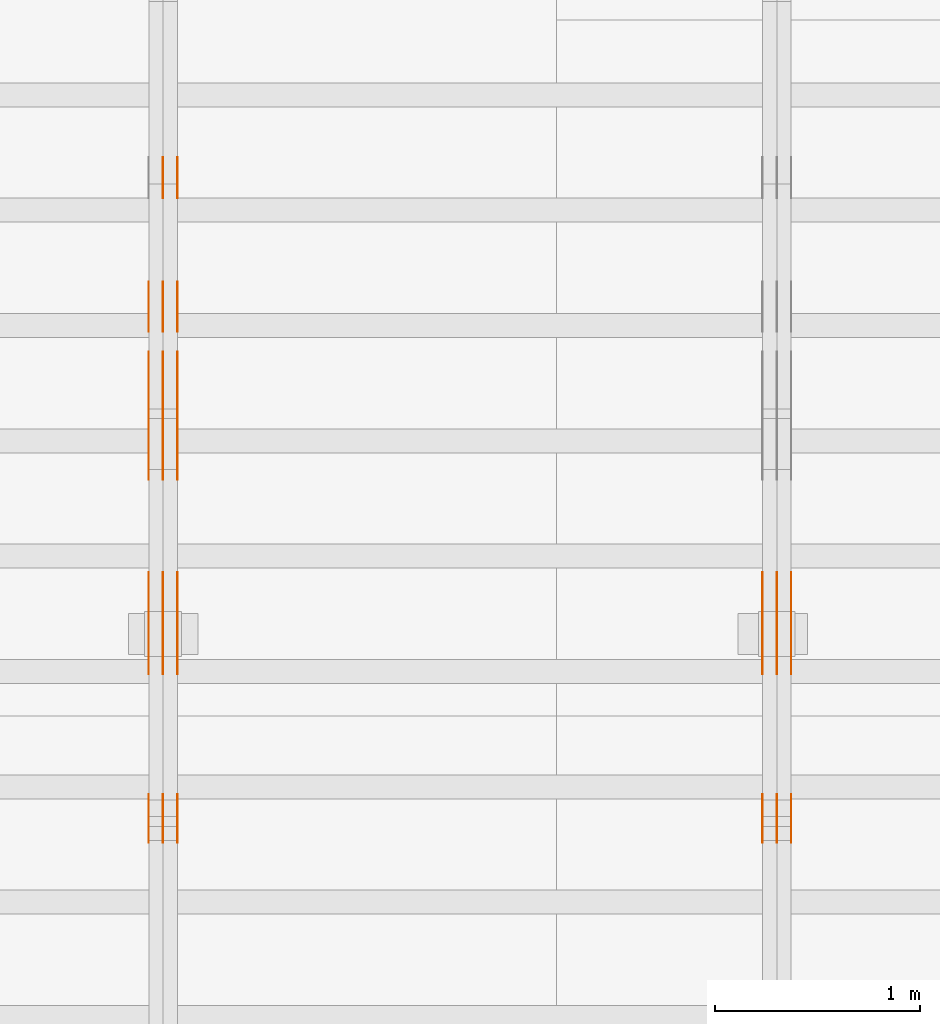
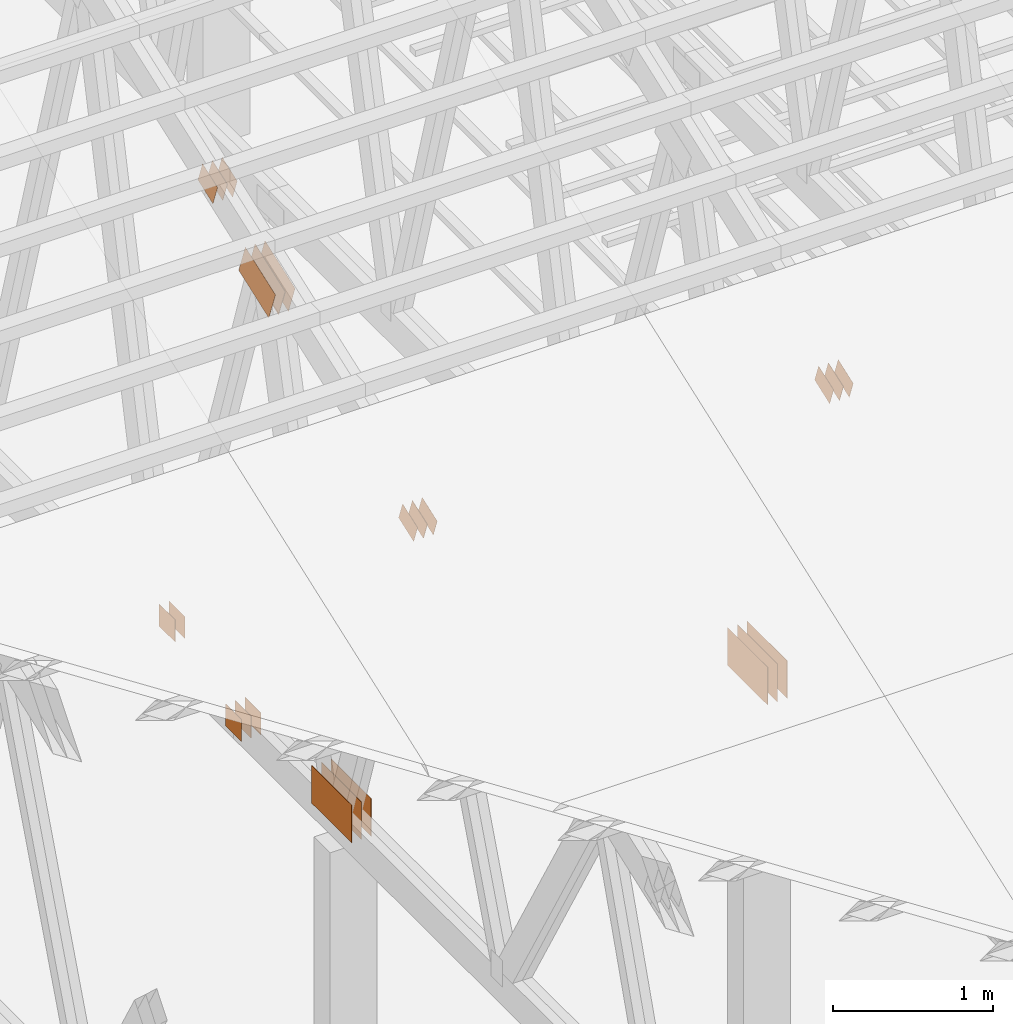
# One storey, part 148 of 189: 31 proxies.
"""IFC2X3 building model written with IfcOpenShell, lengths in millimetres."""

from ifc_helpers import new_model, entity, si_unit, converted_unit, derived_unit, direction, frame, frame_2d, origin, origin_2d_with_axis, place, context, subcontext, project, spatial, polyline, rectangle, outline, extrude, source, transform, mapped, material, type_object, type_shapes, element, save


model = new_model("IFC2X3")

# Units and contexts
model_context = context("Model", 3, precision=0.01, world=origin(), true_north=direction((6.12303176911189e-17, 1.0)))
body_context = subcontext(model_context, "Body", "Model", "MODEL_VIEW")
ifc_project = project(units=[si_unit("LENGTHUNIT", "METRE", prefix="MILLI"), si_unit("AREAUNIT", "SQUARE_METRE"), si_unit("VOLUMEUNIT", "CUBIC_METRE"), converted_unit("PLANEANGLEUNIT", "DEGREE", entity("IfcRatioMeasure", 0.0174532925199433), si_unit("PLANEANGLEUNIT", "RADIAN"), dimensions=[0, 0, 0, 0, 0, 0, 0]), si_unit("MASSUNIT", "GRAM", prefix="KILO"), derived_unit("MASSDENSITYUNIT", [(si_unit("MASSUNIT", "GRAM", prefix="KILO"), 1), (si_unit("LENGTHUNIT", "METRE"), -3)]), si_unit("TIMEUNIT", "SECOND"), si_unit("FREQUENCYUNIT", "HERTZ"), si_unit("THERMODYNAMICTEMPERATUREUNIT", "DEGREE_CELSIUS"), derived_unit("THERMALTRANSMITTANCEUNIT", [(si_unit("MASSUNIT", "GRAM", prefix="KILO"), 1), (si_unit("THERMODYNAMICTEMPERATUREUNIT", "KELVIN"), -1), (si_unit("TIMEUNIT", "SECOND"), -3)]), derived_unit("VOLUMETRICFLOWRATEUNIT", [(si_unit("LENGTHUNIT", "METRE"), 3), (si_unit("TIMEUNIT", "SECOND"), -1)]), si_unit("ELECTRICCURRENTUNIT", "AMPERE"), si_unit("ELECTRICVOLTAGEUNIT", "VOLT"), si_unit("POWERUNIT", "WATT"), si_unit("FORCEUNIT", "NEWTON"), si_unit("ILLUMINANCEUNIT", "LUX"), si_unit("LUMINOUSFLUXUNIT", "LUMEN"), si_unit("LUMINOUSINTENSITYUNIT", "CANDELA"), derived_unit("USERDEFINED", [(si_unit("MASSUNIT", "GRAM", prefix="KILO"), -1), (si_unit("LENGTHUNIT", "METRE"), -2), (si_unit("TIMEUNIT", "SECOND"), 3), (si_unit("LUMINOUSFLUXUNIT", "LUMEN"), 1)]), derived_unit("LINEARVELOCITYUNIT", [(si_unit("LENGTHUNIT", "METRE"), 1), (si_unit("TIMEUNIT", "SECOND"), -1)]), si_unit("PRESSUREUNIT", "PASCAL"), derived_unit("USERDEFINED", [(si_unit("LENGTHUNIT", "METRE"), -2), (si_unit("MASSUNIT", "GRAM", prefix="KILO"), 1), (si_unit("TIMEUNIT", "SECOND"), -2)])], contexts=[model_context])

# Site, building, storey
site_placement = place(None, origin())
site = spatial("IfcSite", under=ifc_project, at=site_placement, CompositionType="ELEMENT")
building_placement = place(site_placement, origin())
building = spatial("IfcBuilding", under=site, at=building_placement, CompositionType="ELEMENT")
storey_placement = place(building_placement, origin())
storey = spatial("IfcBuildingStorey", under=building, at=storey_placement, Name="Default", CompositionType="ELEMENT", Elevation=0.0)

# Proxies
ifc_material_1 = material(Name="IfcSurfaceStyle #233938")
building_element_proxy_type_1 = type_object("IfcBuildingElementProxyType", PredefinedType="NOTDEFINED", material=ifc_material_1)
shared_shape_1 = source(origin(), body_context, "Body", "SweptSolid", [
    extrude(rectangle(XDim=500.0, YDim=288.0, at=frame_2d((0.0, 1.4210854715202e-14), x_axis=(1.0, 0.0))), frame((250.000973740011, 144.0, 0.0), z_axis=(0.0, 0.0, 1.0), x_axis=(-1.0, 0.0, 0.0)), (0.0, 0.0, 1.0), 1.29999999999998),
])
type_shapes(building_element_proxy_type_1, [shared_shape_1])
proxy_1_placement = place(building_placement, frame((42301.3, 8551.90918250999, 389.0), z_axis=(-1.0, 0.0, 0.0), x_axis=(0.0, 1.0, 0.0)))
element("IfcBuildingElementProxy", 1, at=proxy_1_placement, inside=storey, type_object=building_element_proxy_type_1, material=ifc_material_1, context=body_context, shape_type="MappedRepresentation", body=[
    mapped(shared_shape_1, transform((0.0, 0.0, 0.0), scale=1.0)),
])
ifc_material_2 = material(Name="IfcSurfaceStyle #233881")
building_element_proxy_type_2 = type_object("IfcBuildingElementProxyType", PredefinedType="NOTDEFINED", material=ifc_material_2)
shared_shape_2 = source(origin(), body_context, "Body", "SweptSolid", [
    extrude(rectangle(XDim=500.0, YDim=288.0, at=frame_2d((0.0, 1.4210854715202e-14), x_axis=(1.0, 0.0))), frame((250.000973740011, 144.0, 0.0), z_axis=(0.0, 0.0, 1.0), x_axis=(-1.0, 0.0, 0.0)), (0.0, 0.0, 1.0), 1.29999999999997),
])
type_shapes(building_element_proxy_type_2, [shared_shape_2])
proxy_2_placement = place(building_placement, frame((42230.0, 8551.90918250999, 389.0), z_axis=(-1.0, 0.0, 0.0), x_axis=(0.0, 1.0, 0.0)))
element("IfcBuildingElementProxy", 2, at=proxy_2_placement, inside=storey, type_object=building_element_proxy_type_2, material=ifc_material_2, context=body_context, shape_type="MappedRepresentation", body=[
    mapped(shared_shape_2, transform((0.0, 0.0, 0.0), scale=1.0)),
])
ifc_material_3 = material(Name="IfcSurfaceStyle #233824")
building_element_proxy_type_3 = type_object("IfcBuildingElementProxyType", PredefinedType="NOTDEFINED", material=ifc_material_3)
shared_shape_3 = source(origin(), body_context, "Body", "SweptSolid", [
    extrude(rectangle(XDim=500.0, YDim=288.0, at=frame_2d((0.0, 1.4210854715202e-14), x_axis=(1.0, 0.0))), frame((250.000973740011, 144.0, 0.0), z_axis=(0.0, 0.0, 1.0), x_axis=(-1.0, 0.0, 0.0)), (0.0, 0.0, 1.0), 1.29999999999997),
])
type_shapes(building_element_proxy_type_3, [shared_shape_3])
proxy_3_placement = place(building_placement, frame((42231.3, 8551.90918250999, 389.0), z_axis=(-1.0, 0.0, 0.0), x_axis=(0.0, 1.0, 0.0)))
element("IfcBuildingElementProxy", 3, at=proxy_3_placement, inside=storey, type_object=building_element_proxy_type_3, material=ifc_material_3, context=body_context, shape_type="MappedRepresentation", body=[
    mapped(shared_shape_3, transform((0.0, 0.0, 0.0), scale=1.0)),
])
ifc_material_4 = material(Name="IfcSurfaceStyle #233767")
building_element_proxy_type_4 = type_object("IfcBuildingElementProxyType", PredefinedType="NOTDEFINED", material=ifc_material_4)
shared_shape_4 = source(origin(), body_context, "Body", "SweptSolid", [
    extrude(rectangle(XDim=500.0, YDim=288.0, at=frame_2d((0.0, 1.4210854715202e-14), x_axis=(1.0, 0.0))), frame((250.000973740011, 144.0, 0.0), z_axis=(0.0, 0.0, 1.0), x_axis=(-1.0, 0.0, 0.0)), (0.0, 0.0, 1.0), 1.29999999999997),
])
type_shapes(building_element_proxy_type_4, [shared_shape_4])
proxy_4_placement = place(building_placement, frame((42160.0, 8551.90918250999, 389.0), z_axis=(-1.0, 0.0, 0.0), x_axis=(0.0, 1.0, 0.0)))
element("IfcBuildingElementProxy", 4, at=proxy_4_placement, inside=storey, type_object=building_element_proxy_type_4, material=ifc_material_4, context=body_context, shape_type="MappedRepresentation", body=[
    mapped(shared_shape_4, transform((0.0, 0.0, 0.0), scale=1.0)),
])
ifc_material_5 = material(Name="IfcSurfaceStyle #233710")
building_element_proxy_type_5 = type_object("IfcBuildingElementProxyType", PredefinedType="NOTDEFINED", material=ifc_material_5)
shared_shape_5 = source(origin(), body_context, "Body", "SweptSolid", [
    extrude(outline(polyline([(-100.00048713087, -72.0000025659129), (100.000394045495, -72.0000025659129), (99.9995694622958, 72.0000025659129), (-99.9994763769209, 72.0000025659128), (-100.00048713087, -72.0000025659129)])), frame((100.000394045495, 72.0000025659128, 0.0), z_axis=(0.0, 0.0, 1.0), x_axis=(-1.0, 0.0, 0.0)), (0.0, 0.0, 1.0), 1.3),
])
type_shapes(building_element_proxy_type_5, [shared_shape_5])
proxy_5_placement = place(building_placement, frame((42301.3, 7965.16887114408, 2936.19963864386), z_axis=(-1.0, 0.0, 0.0), x_axis=(0.0, -0.939692620785908, -0.342020143325669)))
element("IfcBuildingElementProxy", 5, at=proxy_5_placement, inside=storey, type_object=building_element_proxy_type_5, material=ifc_material_5, context=body_context, shape_type="MappedRepresentation", body=[
    mapped(shared_shape_5, transform((0.0, 0.0, 0.0), scale=1.0)),
])
ifc_material_6 = material(Name="IfcSurfaceStyle #233653")
building_element_proxy_type_6 = type_object("IfcBuildingElementProxyType", PredefinedType="NOTDEFINED", material=ifc_material_6)
shared_shape_6 = source(origin(), body_context, "Body", "SweptSolid", [
    extrude(outline(polyline([(-100.00048713087, -72.0000025659129), (100.000394045495, -72.0000025659129), (99.9995694622958, 72.0000025659129), (-99.9994763769209, 72.0000025659128), (-100.00048713087, -72.0000025659129)])), frame((100.000394045495, 72.0000025659128, 0.0), z_axis=(0.0, 0.0, 1.0), x_axis=(-1.0, 0.0, 0.0)), (0.0, 0.0, 1.0), 1.29999999999998),
])
type_shapes(building_element_proxy_type_6, [shared_shape_6])
proxy_6_placement = place(building_placement, frame((42230.0, 7965.16887114408, 2936.19963864386), z_axis=(-1.0, 0.0, 0.0), x_axis=(0.0, -0.939692620785908, -0.342020143325669)))
element("IfcBuildingElementProxy", 6, at=proxy_6_placement, inside=storey, type_object=building_element_proxy_type_6, material=ifc_material_6, context=body_context, shape_type="MappedRepresentation", body=[
    mapped(shared_shape_6, transform((0.0, 0.0, 0.0), scale=1.0)),
])
ifc_material_7 = material(Name="IfcSurfaceStyle #233596")
building_element_proxy_type_7 = type_object("IfcBuildingElementProxyType", PredefinedType="NOTDEFINED", material=ifc_material_7)
shared_shape_7 = source(origin(), body_context, "Body", "SweptSolid", [
    extrude(outline(polyline([(-100.00048713087, -72.0000025659129), (100.000394045495, -72.0000025659129), (99.9995694622958, 72.0000025659129), (-99.9994763769209, 72.0000025659128), (-100.00048713087, -72.0000025659129)])), frame((100.000394045495, 72.0000025659128, 0.0), z_axis=(0.0, 0.0, 1.0), x_axis=(-1.0, 0.0, 0.0)), (0.0, 0.0, 1.0), 1.29999999999998),
])
type_shapes(building_element_proxy_type_7, [shared_shape_7])
proxy_7_placement = place(building_placement, frame((42231.3, 7965.16887114408, 2936.19963864386), z_axis=(-1.0, 0.0, 0.0), x_axis=(0.0, -0.939692620785908, -0.342020143325669)))
element("IfcBuildingElementProxy", 7, at=proxy_7_placement, inside=storey, type_object=building_element_proxy_type_7, material=ifc_material_7, context=body_context, shape_type="MappedRepresentation", body=[
    mapped(shared_shape_7, transform((0.0, 0.0, 0.0), scale=1.0)),
])
ifc_material_8 = material(Name="IfcSurfaceStyle #233539")
building_element_proxy_type_8 = type_object("IfcBuildingElementProxyType", PredefinedType="NOTDEFINED", material=ifc_material_8)
shared_shape_8 = source(origin(), body_context, "Body", "SweptSolid", [
    extrude(outline(polyline([(-100.00048713087, -72.0000025659129), (100.000394045495, -72.0000025659129), (99.9995694622958, 72.0000025659129), (-99.9994763769209, 72.0000025659128), (-100.00048713087, -72.0000025659129)])), frame((100.000394045495, 72.0000025659128, 0.0), z_axis=(0.0, 0.0, 1.0), x_axis=(-1.0, 0.0, 0.0)), (0.0, 0.0, 1.0), 1.29999999999999),
])
type_shapes(building_element_proxy_type_8, [shared_shape_8])
proxy_8_placement = place(building_placement, frame((42160.0, 7965.16887114408, 2936.19963864386), z_axis=(-1.0, 0.0, 0.0), x_axis=(0.0, -0.939692620785908, -0.342020143325669)))
element("IfcBuildingElementProxy", 8, at=proxy_8_placement, inside=storey, type_object=building_element_proxy_type_8, material=ifc_material_8, context=body_context, shape_type="MappedRepresentation", body=[
    mapped(shared_shape_8, transform((0.0, 0.0, 0.0), scale=1.0)),
])
ifc_material_9 = material(Name="IfcSurfaceStyle #219060")
building_element_proxy_type_9 = type_object("IfcBuildingElementProxyType", PredefinedType="NOTDEFINED", material=ifc_material_9)
shared_shape_9 = source(origin(), body_context, "Body", "SweptSolid", [
    extrude(rectangle(XDim=200.0, YDim=168.0, at=origin_2d_with_axis()), frame((100.000765376775, 84.0, 0.0), z_axis=(0.0, 0.0, 1.0), x_axis=(-1.0, 0.0, 0.0)), (0.0, 0.0, 1.0), 1.3),
])
type_shapes(building_element_proxy_type_9, [shared_shape_9])
proxy_9_placement = place(building_placement, frame((39301.3, 10880.1574377482, 365.0), z_axis=(-1.0, 0.0, 0.0), x_axis=(0.0, 1.0, 0.0)))
element("IfcBuildingElementProxy", 9, at=proxy_9_placement, inside=storey, type_object=building_element_proxy_type_9, material=ifc_material_9, context=body_context, shape_type="MappedRepresentation", body=[
    mapped(shared_shape_9, transform((0.0, 0.0, 0.0), scale=1.0)),
])
ifc_material_10 = material(Name="IfcSurfaceStyle #219003")
building_element_proxy_type_10 = type_object("IfcBuildingElementProxyType", PredefinedType="NOTDEFINED", material=ifc_material_10)
shared_shape_10 = source(origin(), body_context, "Body", "SweptSolid", [
    extrude(rectangle(XDim=200.0, YDim=168.0, at=origin_2d_with_axis()), frame((100.000765376775, 84.0, 0.0), z_axis=(0.0, 0.0, 1.0), x_axis=(-1.0, 0.0, 0.0)), (0.0, 0.0, 1.0), 1.29999999999998),
])
type_shapes(building_element_proxy_type_10, [shared_shape_10])
proxy_10_placement = place(building_placement, frame((39230.0, 10880.1574377482, 365.0), z_axis=(-1.0, 0.0, 0.0), x_axis=(0.0, 1.0, 0.0)))
element("IfcBuildingElementProxy", 10, at=proxy_10_placement, inside=storey, type_object=building_element_proxy_type_10, material=ifc_material_10, context=body_context, shape_type="MappedRepresentation", body=[
    mapped(shared_shape_10, transform((0.0, 0.0, 0.0), scale=1.0)),
])
ifc_material_11 = material(Name="IfcSurfaceStyle #218946")
building_element_proxy_type_11 = type_object("IfcBuildingElementProxyType", PredefinedType="NOTDEFINED", material=ifc_material_11)
shared_shape_11 = source(origin(), body_context, "Body", "SweptSolid", [
    extrude(rectangle(XDim=200.0, YDim=168.0, at=origin_2d_with_axis()), frame((100.000765376775, 84.0, 0.0), z_axis=(0.0, 0.0, 1.0), x_axis=(-1.0, 0.0, 0.0)), (0.0, 0.0, 1.0), 1.29999999999998),
])
type_shapes(building_element_proxy_type_11, [shared_shape_11])
proxy_11_placement = place(building_placement, frame((39231.3, 10880.1574377482, 365.0), z_axis=(-1.0, 0.0, 0.0), x_axis=(0.0, 1.0, 0.0)))
element("IfcBuildingElementProxy", 11, at=proxy_11_placement, inside=storey, type_object=building_element_proxy_type_11, material=ifc_material_11, context=body_context, shape_type="MappedRepresentation", body=[
    mapped(shared_shape_11, transform((0.0, 0.0, 0.0), scale=1.0)),
])
ifc_material_12 = material(Name="IfcSurfaceStyle #218832")
building_element_proxy_type_12 = type_object("IfcBuildingElementProxyType", PredefinedType="NOTDEFINED", material=ifc_material_12)
shared_shape_12 = source(origin(), body_context, "Body", "SweptSolid", [
    extrude(outline(polyline([(-199.999582244654, -119.99984375717), (200.000344770932, -119.99984375717), (199.999582244655, 119.99984375717), (-200.000344770934, 119.99984375717), (-199.999582244654, -119.99984375717)])), frame((200.000344770932, 120.0000091947, 0.0), z_axis=(0.0, 0.0, 1.0), x_axis=(-1.0, 0.0, 0.0)), (0.0, 0.0, 1.0), 1.29999999999999),
])
type_shapes(building_element_proxy_type_12, [shared_shape_12])
proxy_12_placement = place(building_placement, frame((39301.3, 9961.90704972973, 3612.2451494258), z_axis=(-1.0, 0.0, 0.0), x_axis=(0.0, -0.939692620785908, -0.342020143325669)))
element("IfcBuildingElementProxy", 12, at=proxy_12_placement, inside=storey, type_object=building_element_proxy_type_12, material=ifc_material_12, context=body_context, shape_type="MappedRepresentation", body=[
    mapped(shared_shape_12, transform((0.0, 0.0, 0.0), scale=1.0)),
])
ifc_material_13 = material(Name="IfcSurfaceStyle #218775")
building_element_proxy_type_13 = type_object("IfcBuildingElementProxyType", PredefinedType="NOTDEFINED", material=ifc_material_13)
shared_shape_13 = source(origin(), body_context, "Body", "SweptSolid", [
    extrude(outline(polyline([(-199.999582244654, -119.99984375717), (200.000344770932, -119.99984375717), (199.999582244655, 119.99984375717), (-200.000344770934, 119.99984375717), (-199.999582244654, -119.99984375717)])), frame((200.000344770932, 120.0000091947, 0.0), z_axis=(0.0, 0.0, 1.0), x_axis=(-1.0, 0.0, 0.0)), (0.0, 0.0, 1.0), 1.29999999999997),
])
type_shapes(building_element_proxy_type_13, [shared_shape_13])
proxy_13_placement = place(building_placement, frame((39230.0, 9961.90704972973, 3612.2451494258), z_axis=(-1.0, 0.0, 0.0), x_axis=(0.0, -0.939692620785908, -0.342020143325669)))
element("IfcBuildingElementProxy", 13, at=proxy_13_placement, inside=storey, type_object=building_element_proxy_type_13, material=ifc_material_13, context=body_context, shape_type="MappedRepresentation", body=[
    mapped(shared_shape_13, transform((0.0, 0.0, 0.0), scale=1.0)),
])
ifc_material_14 = material(Name="IfcSurfaceStyle #218718")
building_element_proxy_type_14 = type_object("IfcBuildingElementProxyType", PredefinedType="NOTDEFINED", material=ifc_material_14)
shared_shape_14 = source(origin(), body_context, "Body", "SweptSolid", [
    extrude(outline(polyline([(-199.999582244654, -119.99984375717), (200.000344770932, -119.99984375717), (199.999582244655, 119.99984375717), (-200.000344770934, 119.99984375717), (-199.999582244654, -119.99984375717)])), frame((200.000344770932, 120.0000091947, 0.0), z_axis=(0.0, 0.0, 1.0), x_axis=(-1.0, 0.0, 0.0)), (0.0, 0.0, 1.0), 1.29999999999997),
])
type_shapes(building_element_proxy_type_14, [shared_shape_14])
proxy_14_placement = place(building_placement, frame((39231.3, 9961.90704972973, 3612.2451494258), z_axis=(-1.0, 0.0, 0.0), x_axis=(0.0, -0.939692620785908, -0.342020143325669)))
element("IfcBuildingElementProxy", 14, at=proxy_14_placement, inside=storey, type_object=building_element_proxy_type_14, material=ifc_material_14, context=body_context, shape_type="MappedRepresentation", body=[
    mapped(shared_shape_14, transform((0.0, 0.0, 0.0), scale=1.0)),
])
ifc_material_15 = material(Name="IfcSurfaceStyle #218661")
building_element_proxy_type_15 = type_object("IfcBuildingElementProxyType", PredefinedType="NOTDEFINED", material=ifc_material_15)
shared_shape_15 = source(origin(), body_context, "Body", "SweptSolid", [
    extrude(outline(polyline([(-199.999582244654, -119.99984375717), (200.000344770932, -119.99984375717), (199.999582244655, 119.99984375717), (-200.000344770934, 119.99984375717), (-199.999582244654, -119.99984375717)])), frame((200.000344770932, 120.0000091947, 0.0), z_axis=(0.0, 0.0, 1.0), x_axis=(-1.0, 0.0, 0.0)), (0.0, 0.0, 1.0), 1.29999999999998),
])
type_shapes(building_element_proxy_type_15, [shared_shape_15])
proxy_15_placement = place(building_placement, frame((39160.0, 9961.90704972973, 3612.2451494258), z_axis=(-1.0, 0.0, 0.0), x_axis=(0.0, -0.939692620785908, -0.342020143325669)))
element("IfcBuildingElementProxy", 15, at=proxy_15_placement, inside=storey, type_object=building_element_proxy_type_15, material=ifc_material_15, context=body_context, shape_type="MappedRepresentation", body=[
    mapped(shared_shape_15, transform((0.0, 0.0, 0.0), scale=1.0)),
])
ifc_material_16 = material(Name="IfcSurfaceStyle #218148")
building_element_proxy_type_16 = type_object("IfcBuildingElementProxyType", PredefinedType="NOTDEFINED", material=ifc_material_16)
shared_shape_16 = source(origin(), body_context, "Body", "SweptSolid", [
    extrude(rectangle(XDim=500.0, YDim=288.0, at=frame_2d((0.0, 1.4210854715202e-14), x_axis=(1.0, 0.0))), frame((250.000973740011, 144.0, 0.0), z_axis=(0.0, 0.0, 1.0), x_axis=(-1.0, 0.0, 0.0)), (0.0, 0.0, 1.0), 1.29999999999998),
])
type_shapes(building_element_proxy_type_16, [shared_shape_16])
proxy_16_placement = place(building_placement, frame((39301.3, 8551.90918250999, 389.0), z_axis=(-1.0, 0.0, 0.0), x_axis=(0.0, 1.0, 0.0)))
element("IfcBuildingElementProxy", 16, at=proxy_16_placement, inside=storey, type_object=building_element_proxy_type_16, material=ifc_material_16, context=body_context, shape_type="MappedRepresentation", body=[
    mapped(shared_shape_16, transform((0.0, 0.0, 0.0), scale=1.0)),
])
ifc_material_17 = material(Name="IfcSurfaceStyle #218091")
building_element_proxy_type_17 = type_object("IfcBuildingElementProxyType", PredefinedType="NOTDEFINED", material=ifc_material_17)
shared_shape_17 = source(origin(), body_context, "Body", "SweptSolid", [
    extrude(rectangle(XDim=500.0, YDim=288.0, at=frame_2d((0.0, 1.4210854715202e-14), x_axis=(1.0, 0.0))), frame((250.000973740011, 144.0, 0.0), z_axis=(0.0, 0.0, 1.0), x_axis=(-1.0, 0.0, 0.0)), (0.0, 0.0, 1.0), 1.29999999999997),
])
type_shapes(building_element_proxy_type_17, [shared_shape_17])
proxy_17_placement = place(building_placement, frame((39230.0, 8551.90918250999, 389.0), z_axis=(-1.0, 0.0, 0.0), x_axis=(0.0, 1.0, 0.0)))
element("IfcBuildingElementProxy", 17, at=proxy_17_placement, inside=storey, type_object=building_element_proxy_type_17, material=ifc_material_17, context=body_context, shape_type="MappedRepresentation", body=[
    mapped(shared_shape_17, transform((0.0, 0.0, 0.0), scale=1.0)),
])
ifc_material_18 = material(Name="IfcSurfaceStyle #218034")
building_element_proxy_type_18 = type_object("IfcBuildingElementProxyType", PredefinedType="NOTDEFINED", material=ifc_material_18)
shared_shape_18 = source(origin(), body_context, "Body", "SweptSolid", [
    extrude(rectangle(XDim=500.0, YDim=288.0, at=frame_2d((0.0, 1.4210854715202e-14), x_axis=(1.0, 0.0))), frame((250.000973740011, 144.0, 0.0), z_axis=(0.0, 0.0, 1.0), x_axis=(-1.0, 0.0, 0.0)), (0.0, 0.0, 1.0), 1.29999999999997),
])
type_shapes(building_element_proxy_type_18, [shared_shape_18])
proxy_18_placement = place(building_placement, frame((39231.3, 8551.90918250999, 389.0), z_axis=(-1.0, 0.0, 0.0), x_axis=(0.0, 1.0, 0.0)))
element("IfcBuildingElementProxy", 18, at=proxy_18_placement, inside=storey, type_object=building_element_proxy_type_18, material=ifc_material_18, context=body_context, shape_type="MappedRepresentation", body=[
    mapped(shared_shape_18, transform((0.0, 0.0, 0.0), scale=1.0)),
])
ifc_material_19 = material(Name="IfcSurfaceStyle #217977")
building_element_proxy_type_19 = type_object("IfcBuildingElementProxyType", PredefinedType="NOTDEFINED", material=ifc_material_19)
shared_shape_19 = source(origin(), body_context, "Body", "SweptSolid", [
    extrude(rectangle(XDim=500.0, YDim=288.0, at=frame_2d((0.0, 1.4210854715202e-14), x_axis=(1.0, 0.0))), frame((250.000973740011, 144.0, 0.0), z_axis=(0.0, 0.0, 1.0), x_axis=(-1.0, 0.0, 0.0)), (0.0, 0.0, 1.0), 1.29999999999997),
])
type_shapes(building_element_proxy_type_19, [shared_shape_19])
proxy_19_placement = place(building_placement, frame((39160.0, 8551.90918250999, 389.0), z_axis=(-1.0, 0.0, 0.0), x_axis=(0.0, 1.0, 0.0)))
element("IfcBuildingElementProxy", 19, at=proxy_19_placement, inside=storey, type_object=building_element_proxy_type_19, material=ifc_material_19, context=body_context, shape_type="MappedRepresentation", body=[
    mapped(shared_shape_19, transform((0.0, 0.0, 0.0), scale=1.0)),
])
ifc_material_20 = material(Name="IfcSurfaceStyle #217920")
building_element_proxy_type_20 = type_object("IfcBuildingElementProxyType", PredefinedType="NOTDEFINED", material=ifc_material_20)
shared_shape_20 = source(origin(), body_context, "Body", "SweptSolid", [
    extrude(outline(polyline([(-100.00048713087, -72.0000025659129), (100.000394045495, -72.0000025659129), (99.9995694622958, 72.0000025659129), (-99.9994763769209, 72.0000025659128), (-100.00048713087, -72.0000025659129)])), frame((100.000394045495, 72.0000025659128, 0.0), z_axis=(0.0, 0.0, 1.0), x_axis=(-1.0, 0.0, 0.0)), (0.0, 0.0, 1.0), 1.3),
])
type_shapes(building_element_proxy_type_20, [shared_shape_20])
proxy_20_placement = place(building_placement, frame((39301.3, 7965.16887114408, 2936.19963864386), z_axis=(-1.0, 0.0, 0.0), x_axis=(0.0, -0.939692620785908, -0.342020143325669)))
element("IfcBuildingElementProxy", 20, at=proxy_20_placement, inside=storey, type_object=building_element_proxy_type_20, material=ifc_material_20, context=body_context, shape_type="MappedRepresentation", body=[
    mapped(shared_shape_20, transform((0.0, 0.0, 0.0), scale=1.0)),
])
ifc_material_21 = material(Name="IfcSurfaceStyle #217863")
building_element_proxy_type_21 = type_object("IfcBuildingElementProxyType", PredefinedType="NOTDEFINED", material=ifc_material_21)
shared_shape_21 = source(origin(), body_context, "Body", "SweptSolid", [
    extrude(outline(polyline([(-100.00048713087, -72.0000025659129), (100.000394045495, -72.0000025659129), (99.9995694622958, 72.0000025659129), (-99.9994763769209, 72.0000025659128), (-100.00048713087, -72.0000025659129)])), frame((100.000394045495, 72.0000025659128, 0.0), z_axis=(0.0, 0.0, 1.0), x_axis=(-1.0, 0.0, 0.0)), (0.0, 0.0, 1.0), 1.29999999999998),
])
type_shapes(building_element_proxy_type_21, [shared_shape_21])
proxy_21_placement = place(building_placement, frame((39230.0, 7965.16887114408, 2936.19963864386), z_axis=(-1.0, 0.0, 0.0), x_axis=(0.0, -0.939692620785908, -0.342020143325669)))
element("IfcBuildingElementProxy", 21, at=proxy_21_placement, inside=storey, type_object=building_element_proxy_type_21, material=ifc_material_21, context=body_context, shape_type="MappedRepresentation", body=[
    mapped(shared_shape_21, transform((0.0, 0.0, 0.0), scale=1.0)),
])
ifc_material_22 = material(Name="IfcSurfaceStyle #217806")
building_element_proxy_type_22 = type_object("IfcBuildingElementProxyType", PredefinedType="NOTDEFINED", material=ifc_material_22)
shared_shape_22 = source(origin(), body_context, "Body", "SweptSolid", [
    extrude(outline(polyline([(-100.00048713087, -72.0000025659129), (100.000394045495, -72.0000025659129), (99.9995694622958, 72.0000025659129), (-99.9994763769209, 72.0000025659128), (-100.00048713087, -72.0000025659129)])), frame((100.000394045495, 72.0000025659128, 0.0), z_axis=(0.0, 0.0, 1.0), x_axis=(-1.0, 0.0, 0.0)), (0.0, 0.0, 1.0), 1.29999999999998),
])
type_shapes(building_element_proxy_type_22, [shared_shape_22])
proxy_22_placement = place(building_placement, frame((39231.3, 7965.16887114408, 2936.19963864386), z_axis=(-1.0, 0.0, 0.0), x_axis=(0.0, -0.939692620785908, -0.342020143325669)))
element("IfcBuildingElementProxy", 22, at=proxy_22_placement, inside=storey, type_object=building_element_proxy_type_22, material=ifc_material_22, context=body_context, shape_type="MappedRepresentation", body=[
    mapped(shared_shape_22, transform((0.0, 0.0, 0.0), scale=1.0)),
])
ifc_material_23 = material(Name="IfcSurfaceStyle #217749")
building_element_proxy_type_23 = type_object("IfcBuildingElementProxyType", PredefinedType="NOTDEFINED", material=ifc_material_23)
shared_shape_23 = source(origin(), body_context, "Body", "SweptSolid", [
    extrude(outline(polyline([(-100.00048713087, -72.0000025659129), (100.000394045495, -72.0000025659129), (99.9995694622958, 72.0000025659129), (-99.9994763769209, 72.0000025659128), (-100.00048713087, -72.0000025659129)])), frame((100.000394045495, 72.0000025659128, 0.0), z_axis=(0.0, 0.0, 1.0), x_axis=(-1.0, 0.0, 0.0)), (0.0, 0.0, 1.0), 1.29999999999999),
])
type_shapes(building_element_proxy_type_23, [shared_shape_23])
proxy_23_placement = place(building_placement, frame((39160.0, 7965.16887114408, 2936.19963864386), z_axis=(-1.0, 0.0, 0.0), x_axis=(0.0, -0.939692620785908, -0.342020143325669)))
element("IfcBuildingElementProxy", 23, at=proxy_23_placement, inside=storey, type_object=building_element_proxy_type_23, material=ifc_material_23, context=body_context, shape_type="MappedRepresentation", body=[
    mapped(shared_shape_23, transform((0.0, 0.0, 0.0), scale=1.0)),
])
ifc_material_24 = material(Name="IfcSurfaceStyle #212508")
building_element_proxy_type_24 = type_object("IfcBuildingElementProxyType", PredefinedType="NOTDEFINED", material=ifc_material_24)
shared_shape_24 = source(origin(), body_context, "Body", "SweptSolid", [
    extrude(rectangle(XDim=200.0, YDim=168.0, at=origin_2d_with_axis()), frame((100.0, 84.0, 0.0), z_axis=(0.0, 0.0, 1.0), x_axis=(-1.0, 0.0, 0.0)), (0.0, 0.0, 1.0), 1.3),
])
type_shapes(building_element_proxy_type_24, [shared_shape_24])
proxy_24_placement = place(building_placement, frame((39301.3, 9929.23046875, 206.5), z_axis=(-1.0, 0.0, 0.0), x_axis=(0.0, 1.0, 0.0)))
element("IfcBuildingElementProxy", 24, at=proxy_24_placement, inside=storey, type_object=building_element_proxy_type_24, material=ifc_material_24, context=body_context, shape_type="MappedRepresentation", body=[
    mapped(shared_shape_24, transform((0.0, 0.0, 0.0), scale=1.0)),
])
ifc_material_25 = material(Name="IfcSurfaceStyle #212451")
building_element_proxy_type_25 = type_object("IfcBuildingElementProxyType", PredefinedType="NOTDEFINED", material=ifc_material_25)
shared_shape_25 = source(origin(), body_context, "Body", "SweptSolid", [
    extrude(rectangle(XDim=200.0, YDim=168.0, at=origin_2d_with_axis()), frame((100.0, 84.0, 0.0), z_axis=(0.0, 0.0, 1.0), x_axis=(-1.0, 0.0, 0.0)), (0.0, 0.0, 1.0), 1.29999999999998),
])
type_shapes(building_element_proxy_type_25, [shared_shape_25])
proxy_25_placement = place(building_placement, frame((39230.0, 9929.23046875, 206.5), z_axis=(-1.0, 0.0, 0.0), x_axis=(0.0, 1.0, 0.0)))
element("IfcBuildingElementProxy", 25, at=proxy_25_placement, inside=storey, type_object=building_element_proxy_type_25, material=ifc_material_25, context=body_context, shape_type="MappedRepresentation", body=[
    mapped(shared_shape_25, transform((0.0, 0.0, 0.0), scale=1.0)),
])
ifc_material_26 = material(Name="IfcSurfaceStyle #212394")
building_element_proxy_type_26 = type_object("IfcBuildingElementProxyType", PredefinedType="NOTDEFINED", material=ifc_material_26)
shared_shape_26 = source(origin(), body_context, "Body", "SweptSolid", [
    extrude(rectangle(XDim=200.0, YDim=168.0, at=origin_2d_with_axis()), frame((100.0, 84.0, 0.0), z_axis=(0.0, 0.0, 1.0), x_axis=(-1.0, 0.0, 0.0)), (0.0, 0.0, 1.0), 1.29999999999998),
])
type_shapes(building_element_proxy_type_26, [shared_shape_26])
proxy_26_placement = place(building_placement, frame((39231.3, 9929.23046875, 206.5), z_axis=(-1.0, 0.0, 0.0), x_axis=(0.0, 1.0, 0.0)))
element("IfcBuildingElementProxy", 26, at=proxy_26_placement, inside=storey, type_object=building_element_proxy_type_26, material=ifc_material_26, context=body_context, shape_type="MappedRepresentation", body=[
    mapped(shared_shape_26, transform((0.0, 0.0, 0.0), scale=1.0)),
])
ifc_material_27 = material(Name="IfcSurfaceStyle #212337")
building_element_proxy_type_27 = type_object("IfcBuildingElementProxyType", PredefinedType="NOTDEFINED", material=ifc_material_27)
shared_shape_27 = source(origin(), body_context, "Body", "SweptSolid", [
    extrude(rectangle(XDim=200.0, YDim=168.0, at=origin_2d_with_axis()), frame((100.0, 84.0, 0.0), z_axis=(0.0, 0.0, 1.0), x_axis=(-1.0, 0.0, 0.0)), (0.0, 0.0, 1.0), 1.29999999999999),
])
type_shapes(building_element_proxy_type_27, [shared_shape_27])
proxy_27_placement = place(building_placement, frame((39160.0, 9929.23046875, 206.5), z_axis=(-1.0, 0.0, 0.0), x_axis=(0.0, 1.0, 0.0)))
element("IfcBuildingElementProxy", 27, at=proxy_27_placement, inside=storey, type_object=building_element_proxy_type_27, material=ifc_material_27, context=body_context, shape_type="MappedRepresentation", body=[
    mapped(shared_shape_27, transform((0.0, 0.0, 0.0), scale=1.0)),
])
ifc_material_28 = material(Name="IfcSurfaceStyle #211428")
building_element_proxy_type_28 = type_object("IfcBuildingElementProxyType", PredefinedType="NOTDEFINED", material=ifc_material_28)
shared_shape_28 = source(origin(), body_context, "Body", "SweptSolid", [
    extrude(outline(polyline([(-100.00072430513, -84.0000258989549), (100.000156871239, -84.0000258989549), (99.9997648860508, 84.0000258989549), (-99.9991974521591, 84.0000258989548), (-100.00072430513, -84.0000258989549)])), frame((100.000156871239, 84.0000258989548, 0.0), z_axis=(0.0, 0.0, 1.0), x_axis=(-1.0, 0.0, 0.0)), (0.0, 0.0, 1.0), 1.3),
])
type_shapes(building_element_proxy_type_28, [shared_shape_28])
proxy_28_placement = place(building_placement, frame((39301.3, 10226.4409888304, 4081.14941482552), z_axis=(-1.0, 0.0, 0.0), x_axis=(0.0, 0.939692620785908, 0.342020143325669)))
element("IfcBuildingElementProxy", 28, at=proxy_28_placement, inside=storey, type_object=building_element_proxy_type_28, material=ifc_material_28, context=body_context, shape_type="MappedRepresentation", body=[
    mapped(shared_shape_28, transform((0.0, 0.0, 0.0), scale=1.0)),
])
ifc_material_29 = material(Name="IfcSurfaceStyle #211371")
building_element_proxy_type_29 = type_object("IfcBuildingElementProxyType", PredefinedType="NOTDEFINED", material=ifc_material_29)
shared_shape_29 = source(origin(), body_context, "Body", "SweptSolid", [
    extrude(outline(polyline([(-100.00072430513, -84.0000258989549), (100.000156871239, -84.0000258989549), (99.9997648860508, 84.0000258989549), (-99.9991974521591, 84.0000258989548), (-100.00072430513, -84.0000258989549)])), frame((100.000156871239, 84.0000258989548, 0.0), z_axis=(0.0, 0.0, 1.0), x_axis=(-1.0, 0.0, 0.0)), (0.0, 0.0, 1.0), 1.29999999999998),
])
type_shapes(building_element_proxy_type_29, [shared_shape_29])
proxy_29_placement = place(building_placement, frame((39230.0, 10226.4409888304, 4081.14941482552), z_axis=(-1.0, 0.0, 0.0), x_axis=(0.0, 0.939692620785908, 0.342020143325669)))
element("IfcBuildingElementProxy", 29, at=proxy_29_placement, inside=storey, type_object=building_element_proxy_type_29, material=ifc_material_29, context=body_context, shape_type="MappedRepresentation", body=[
    mapped(shared_shape_29, transform((0.0, 0.0, 0.0), scale=1.0)),
])
ifc_material_30 = material(Name="IfcSurfaceStyle #211314")
building_element_proxy_type_30 = type_object("IfcBuildingElementProxyType", PredefinedType="NOTDEFINED", material=ifc_material_30)
shared_shape_30 = source(origin(), body_context, "Body", "SweptSolid", [
    extrude(outline(polyline([(-100.00072430513, -84.0000258989549), (100.000156871239, -84.0000258989549), (99.9997648860508, 84.0000258989549), (-99.9991974521591, 84.0000258989548), (-100.00072430513, -84.0000258989549)])), frame((100.000156871239, 84.0000258989548, 0.0), z_axis=(0.0, 0.0, 1.0), x_axis=(-1.0, 0.0, 0.0)), (0.0, 0.0, 1.0), 1.29999999999998),
])
type_shapes(building_element_proxy_type_30, [shared_shape_30])
proxy_30_placement = place(building_placement, frame((39231.3, 10226.4409888304, 4081.14941482552), z_axis=(-1.0, 0.0, 0.0), x_axis=(0.0, 0.939692620785908, 0.342020143325669)))
element("IfcBuildingElementProxy", 30, at=proxy_30_placement, inside=storey, type_object=building_element_proxy_type_30, material=ifc_material_30, context=body_context, shape_type="MappedRepresentation", body=[
    mapped(shared_shape_30, transform((0.0, 0.0, 0.0), scale=1.0)),
])
ifc_material_31 = material(Name="IfcSurfaceStyle #211257")
building_element_proxy_type_31 = type_object("IfcBuildingElementProxyType", PredefinedType="NOTDEFINED", material=ifc_material_31)
shared_shape_31 = source(origin(), body_context, "Body", "SweptSolid", [
    extrude(outline(polyline([(-100.00072430513, -84.0000258989549), (100.000156871239, -84.0000258989549), (99.9997648860508, 84.0000258989549), (-99.9991974521591, 84.0000258989548), (-100.00072430513, -84.0000258989549)])), frame((100.000156871239, 84.0000258989548, 0.0), z_axis=(0.0, 0.0, 1.0), x_axis=(-1.0, 0.0, 0.0)), (0.0, 0.0, 1.0), 1.29999999999999),
])
type_shapes(building_element_proxy_type_31, [shared_shape_31])
proxy_31_placement = place(building_placement, frame((39160.0, 10226.4409888304, 4081.14941482552), z_axis=(-1.0, 0.0, 0.0), x_axis=(0.0, 0.939692620785908, 0.342020143325669)))
element("IfcBuildingElementProxy", 31, at=proxy_31_placement, inside=storey, type_object=building_element_proxy_type_31, material=ifc_material_31, context=body_context, shape_type="MappedRepresentation", body=[
    mapped(shared_shape_31, transform((0.0, 0.0, 0.0), scale=1.0)),
])

save(model, "model.ifc")
